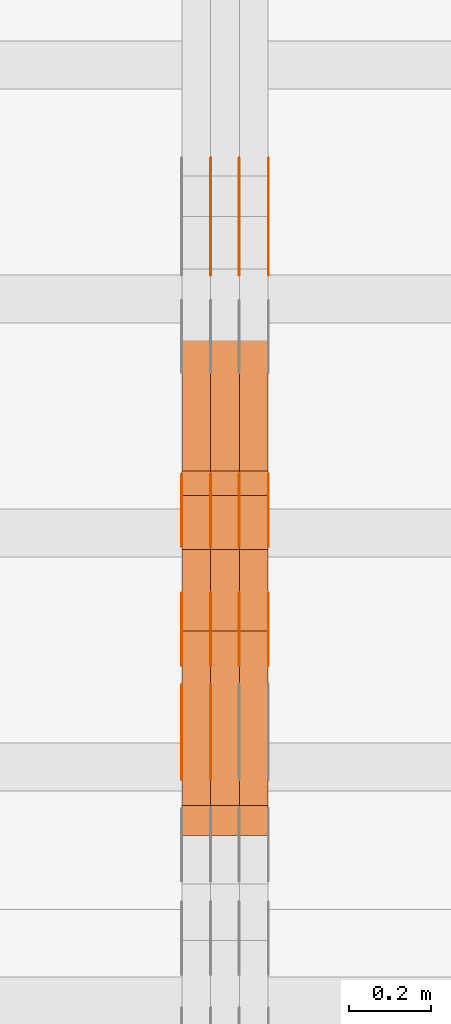
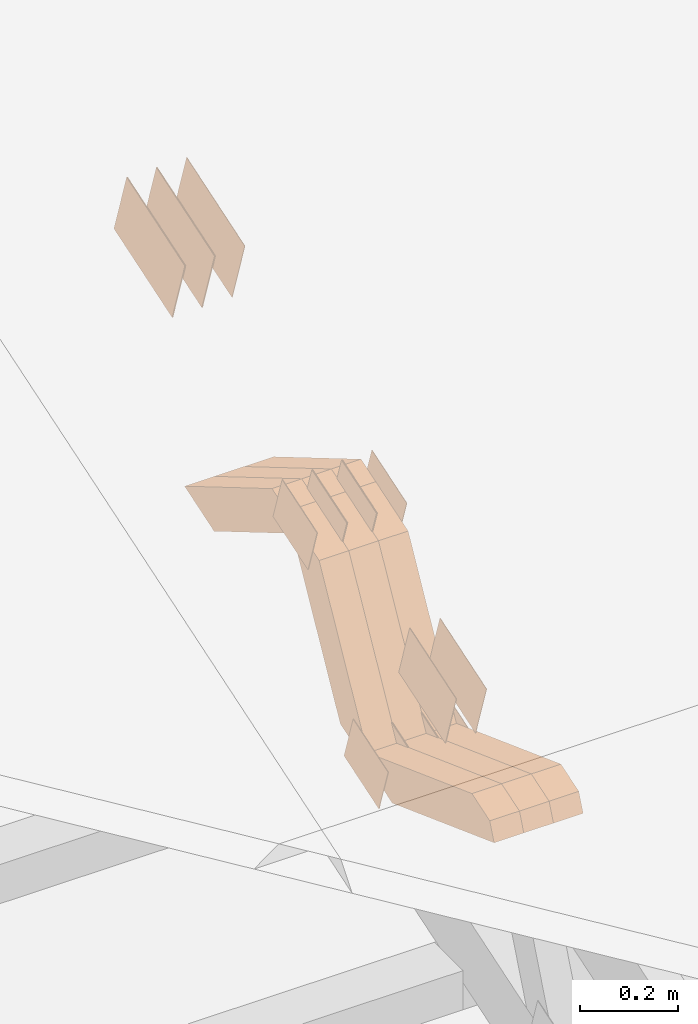
# One storey, part 120 of 385: 28 proxies.
"""IFC2X3 building model written with IfcOpenShell, lengths in millimetres."""

import ifcopenshell
import ifcopenshell.guid

model = None  # the IFC model being written
_history = None  # IfcOwnerHistory: only IFC2X3 demands one
_inside = {}  # id of a spatial element -> (the spatial element, [elements in it])
_under = {}  # id of a project, library or spatial element -> (it, [spatial elements below it])
_declared = {}  # id of a project -> (the project, [libraries it declares])
_typed = {}  # id of a type object -> (the type object, [elements of that type])
_made_of = {}  # id of a material, layer set ... -> (it, [elements and type objects made of it])


def new_model(schema):
    """Start an empty IFC model of exactly this schema.

    Asked for "IFC4X3", IfcOpenShell would pick the latest addendum, in which some entities
    have other attributes; the version numbers below select the first issue.
    IFC2X3 requires an IfcOwnerHistory on every rooted entity: one is made here for all.
    """
    global model, _history
    if schema == "IFC4X3":
        model = ifcopenshell.file(schema_version=(4, 3, 0, 0))
    else:
        model = ifcopenshell.file(schema=schema)
    _inside.clear()
    _under.clear()
    _declared.clear()
    _typed.clear()
    _made_of.clear()
    _history = None
    if model.schema == "IFC2X3":
        org = make("IfcOrganization", Name="unknown")
        user = make(
            "IfcPersonAndOrganization",
            ThePerson=make("IfcPerson", FamilyName="unknown"),
            TheOrganization=org,
        )
        app = make(
            "IfcApplication",
            ApplicationDeveloper=org,
            Version="unknown",
            ApplicationFullName="unknown",
            ApplicationIdentifier="unknown",
        )
        _history = make(
            "IfcOwnerHistory",
            OwningUser=user,
            OwningApplication=app,
            ChangeAction="ADDED",
            CreationDate=0,
        )
    return model


def make(cls, **values):
    """One entity of the class cls with the attributes given. An attribute that is None is left unset."""
    return model.create_entity(
        cls, **{name: value for name, value in values.items() if value is not None}
    )


def entity(cls, *values):
    """Any entity or typed value of the class cls, its attributes in the order of the schema. None: left unset."""
    e = model.create_entity(cls)
    for i, value in enumerate(values):
        if value is not None:
            e[i] = value
    return e


def rooted(cls, **values):
    """An entity with a GlobalId (a new one), such as an element, a storey or a relation."""
    return make(cls, GlobalId=ifcopenshell.guid.new(), OwnerHistory=_history, **values)


def si_unit(unit_type, name, prefix=None):
    """IfcSIUnit, for example si_unit("LENGTHUNIT", "METRE", prefix="MILLI")."""
    return make("IfcSIUnit", UnitType=unit_type, Prefix=prefix, Name=name)


def converted_unit(unit_type, name, factor, base, dimensions=None, offset=None):
    """IfcConversionBasedUnit, such as the inch: factor (a typed value) times the base unit."""
    return make(
        "IfcConversionBasedUnit"
        if offset is None
        else "IfcConversionBasedUnitWithOffset",
        ConversionOffset=offset,
        Dimensions=None
        if dimensions is None
        else entity("IfcDimensionalExponents", *dimensions),
        UnitType=unit_type,
        Name=name,
        ConversionFactor=make(
            "IfcMeasureWithUnit", ValueComponent=factor, UnitComponent=base
        ),
    )


def derived_unit(unit_type, elements):
    """IfcDerivedUnit: a product of units, each with its exponent."""
    return make(
        "IfcDerivedUnit",
        Elements=[
            make("IfcDerivedUnitElement", Unit=unit, Exponent=power)
            for unit, power in elements
        ],
        UnitType=unit_type,
    )


def assignment(units):
    """IfcUnitAssignment: the units of a project."""
    return None if units is None else make("IfcUnitAssignment", Units=units)


def point(xyz):
    """IfcCartesianPoint."""
    return None if xyz is None else make("IfcCartesianPoint", Coordinates=xyz)


def direction(xyz):
    """IfcDirection."""
    return None if xyz is None else make("IfcDirection", DirectionRatios=xyz)


def frame(location, z_axis=None, x_axis=None):
    """IfcAxis2Placement3D, a coordinate frame: its origin and axes. An axis left out is left unset."""
    return make(
        "IfcAxis2Placement3D",
        Location=point(location),
        Axis=direction(z_axis),
        RefDirection=direction(x_axis),
    )


def origin():
    """The frame at (0, 0, 0) with its axes left unset."""
    return frame((0.0, 0.0, 0.0))


def place(relative_to, where):
    """IfcLocalPlacement: puts the frame where relative to a parent placement (None: the world)."""
    return make(
        "IfcLocalPlacement", PlacementRelTo=relative_to, RelativePlacement=where
    )


def context(
    kind, dimensions, precision=None, world=None, true_north=None, identifier=None
):
    """IfcGeometricRepresentationContext, for example the 3D "Model" context."""
    return make(
        "IfcGeometricRepresentationContext",
        ContextIdentifier=identifier,
        ContextType=kind,
        CoordinateSpaceDimension=dimensions,
        Precision=precision,
        WorldCoordinateSystem=world,
        TrueNorth=true_north,
    )


def subcontext(parent, identifier, kind, view, scale=None):
    """IfcGeometricRepresentationSubContext, for example "Body" below "Model"."""
    return make(
        "IfcGeometricRepresentationSubContext",
        ContextIdentifier=identifier,
        ContextType=kind,
        ParentContext=parent,
        TargetScale=scale,
        TargetView=view,
    )


def project(units=None, contexts=None):
    """IfcProject with its units and contexts."""
    return rooted(
        "IfcProject",
        Name="project",
        RepresentationContexts=contexts,
        UnitsInContext=assignment(units),
    )


def spatial(cls, under=None, at=None, **own):
    """A site, building, storey or space (cls), placed at a placement, below another one or the project."""
    s = rooted(cls, ObjectPlacement=at, **own)
    if under is not None:
        _under.setdefault(under.id(), (under, []))[1].append(s)
    return s


def polyline(points):
    """IfcPolyline through the points."""
    return make("IfcPolyline", Points=[point(p) for p in points])


def outline(outer, holes=None, kind="AREA"):
    """IfcArbitraryClosedProfileDef: a profile drawn as a closed curve; with holes, ...WithVoids."""
    if holes is None:
        return make("IfcArbitraryClosedProfileDef", ProfileType=kind, OuterCurve=outer)
    return make(
        "IfcArbitraryProfileDefWithVoids",
        ProfileType=kind,
        OuterCurve=outer,
        InnerCurves=holes,
    )


def extrude(swept, where, along, depth):
    """IfcExtrudedAreaSolid: the profile swept, set in the frame where, extruded along a direction by depth."""
    return make(
        "IfcExtrudedAreaSolid",
        SweptArea=swept,
        Position=where,
        ExtrudedDirection=direction(along),
        Depth=depth,
    )


def shape(context_of_items, identifier, shape_type, items):
    """IfcShapeRepresentation: the items that make up one representation, for example the "Body"."""
    return make(
        "IfcShapeRepresentation",
        ContextOfItems=context_of_items,
        RepresentationIdentifier=identifier,
        RepresentationType=shape_type,
        Items=items,
    )


def source(mapping_origin, context_of_items, identifier, shape_type, items):
    """IfcRepresentationMap: a shape defined once, which mapped items show again and again."""
    return make(
        "IfcRepresentationMap",
        MappingOrigin=mapping_origin,
        MappedRepresentation=shape(context_of_items, identifier, shape_type, items),
    )


def transform(
    local_origin,
    x_axis=None,
    y_axis=None,
    z_axis=None,
    scale=None,
    scale2=None,
    scale3=None,
    uniform=True,
):
    """IfcCartesianTransformationOperator3D, or its non-uniform kind. x_axis, y_axis, z_axis: its Axis1, 2, 3."""
    if uniform:
        return make(
            "IfcCartesianTransformationOperator3D",
            Axis1=direction(x_axis),
            Axis2=direction(y_axis),
            LocalOrigin=point(local_origin),
            Scale=scale,
            Axis3=direction(z_axis),
        )
    return make(
        "IfcCartesianTransformationOperator3DnonUniform",
        Axis1=direction(x_axis),
        Axis2=direction(y_axis),
        LocalOrigin=point(local_origin),
        Scale=scale,
        Axis3=direction(z_axis),
        Scale2=scale2,
        Scale3=scale3,
    )


def mapped(mapping_source, mapping_target):
    """IfcMappedItem: shows the shape of a source again, moved by a transform."""
    return make(
        "IfcMappedItem", MappingSource=mapping_source, MappingTarget=mapping_target
    )


def material(Name=None, Category=None):
    """IfcMaterial."""
    return make("IfcMaterial", Name=Name, Category=Category)


def made_of(thing, what):
    """Note that an element or type object is made of a material, layer set ...; save() writes the relation."""
    if what is not None:
        _made_of.setdefault(what.id(), (what, []))[1].append(thing)
    return thing


def type_object(cls, material=None, **own):
    """A type object (cls), such as IfcWallType, which elements share."""
    return made_of(rooted(cls, **own), material)


def type_shapes(of_type, sources):
    """Give a type object the sources (RepresentationMaps) that its elements show as mapped items."""
    of_type.RepresentationMaps = sources


def element(
    cls,
    number,
    at=None,
    inside=None,
    cuts=None,
    type_object=None,
    material=None,
    context=None,
    identifier="Body",
    shape_type=None,
    held_by="IfcProductDefinitionShape",
    body=None,
    shapes=None,
    **own,
):
    """One element of the class cls, such as IfcWall. Its Tag is "e" and its number.

    at: its placement. inside: the storey or other place that contains it. cuts: it is an
    opening in that element (IfcRelVoidsElement). A single representation is given by context,
    identifier, shape_type and body (its items); several are given by shapes. held_by: the class
    of the entity that holds the representations. save() writes the other relations.
    """
    e = rooted(cls, Tag="e%d" % number, ObjectPlacement=at, **own)
    if body is not None:
        shapes = [shape(context, identifier, shape_type, body)]
    if shapes is not None:
        e.Representation = make(held_by, Representations=shapes)
    if inside is not None:
        _inside.setdefault(inside.id(), (inside, []))[1].append(e)
    if cuts is not None:
        rooted(
            "IfcRelVoidsElement", RelatingBuildingElement=cuts, RelatedOpeningElement=e
        )
    if type_object is not None:
        _typed.setdefault(type_object.id(), (type_object, []))[1].append(e)
    return made_of(e, material)


def aggregate(whole, parts):
    """IfcRelAggregates: a whole, such as a stair, and the parts it consists of."""
    return rooted("IfcRelAggregates", RelatingObject=whole, RelatedObjects=parts)


def save(model, path):
    """Write the relations noted so far, then the file.

    IfcRelAggregates (storeys below a building ...), IfcRelContainedInSpatialStructure (elements
    in a storey), IfcRelDefinesByType, IfcRelAssociatesMaterial and IfcRelDeclares: one each for
    every whole, place, type object, material and project.
    """
    for whole, parts in _under.values():
        aggregate(whole, parts)
    for where, things in _inside.values():
        rooted(
            "IfcRelContainedInSpatialStructure",
            RelatedElements=things,
            RelatingStructure=where,
        )
    for kind, things in _typed.values():
        rooted("IfcRelDefinesByType", RelatedObjects=things, RelatingType=kind)
    for what, things in _made_of.values():
        rooted("IfcRelAssociatesMaterial", RelatedObjects=things, RelatingMaterial=what)
    for by, libraries in _declared.values():
        rooted("IfcRelDeclares", RelatingContext=by, RelatedDefinitions=libraries)
    model.write(path)


model = new_model("IFC2X3")

# Units and contexts
model_context = context("Model", 3, precision=0.01, world=origin(), true_north=direction((6.12303176911189e-17, 1.0)))
body_context = subcontext(model_context, "Body", "Model", "MODEL_VIEW")
ifc_project = project(units=[si_unit("LENGTHUNIT", "METRE", prefix="MILLI"), si_unit("AREAUNIT", "SQUARE_METRE"), si_unit("VOLUMEUNIT", "CUBIC_METRE"), converted_unit("PLANEANGLEUNIT", "DEGREE", entity("IfcRatioMeasure", 0.0174532925199433), si_unit("PLANEANGLEUNIT", "RADIAN"), dimensions=[0, 0, 0, 0, 0, 0, 0]), si_unit("MASSUNIT", "GRAM", prefix="KILO"), derived_unit("MASSDENSITYUNIT", [(si_unit("MASSUNIT", "GRAM", prefix="KILO"), 1), (si_unit("LENGTHUNIT", "METRE"), -3)]), si_unit("TIMEUNIT", "SECOND"), si_unit("FREQUENCYUNIT", "HERTZ"), si_unit("THERMODYNAMICTEMPERATUREUNIT", "DEGREE_CELSIUS"), derived_unit("THERMALTRANSMITTANCEUNIT", [(si_unit("MASSUNIT", "GRAM", prefix="KILO"), 1), (si_unit("THERMODYNAMICTEMPERATUREUNIT", "KELVIN"), -1), (si_unit("TIMEUNIT", "SECOND"), -3)]), derived_unit("VOLUMETRICFLOWRATEUNIT", [(si_unit("LENGTHUNIT", "METRE"), 3), (si_unit("TIMEUNIT", "SECOND"), -1)]), si_unit("ELECTRICCURRENTUNIT", "AMPERE"), si_unit("ELECTRICVOLTAGEUNIT", "VOLT"), si_unit("POWERUNIT", "WATT"), si_unit("FORCEUNIT", "NEWTON", prefix="KILO"), si_unit("ILLUMINANCEUNIT", "LUX"), si_unit("LUMINOUSFLUXUNIT", "LUMEN"), si_unit("LUMINOUSINTENSITYUNIT", "CANDELA"), derived_unit("USERDEFINED", [(si_unit("MASSUNIT", "GRAM", prefix="KILO"), -1), (si_unit("LENGTHUNIT", "METRE"), -2), (si_unit("TIMEUNIT", "SECOND"), 3), (si_unit("LUMINOUSFLUXUNIT", "LUMEN"), 1)]), derived_unit("LINEARVELOCITYUNIT", [(si_unit("LENGTHUNIT", "METRE"), 1), (si_unit("TIMEUNIT", "SECOND"), -1)]), si_unit("PRESSUREUNIT", "PASCAL"), derived_unit("USERDEFINED", [(si_unit("LENGTHUNIT", "METRE"), -2), (si_unit("MASSUNIT", "GRAM", prefix="KILO"), 1), (si_unit("TIMEUNIT", "SECOND"), -2)])], contexts=[model_context])

# Site, building, storey
site_placement = place(None, origin())
site = spatial("IfcSite", under=ifc_project, at=site_placement, CompositionType="ELEMENT")
building_placement = place(site_placement, origin())
building = spatial("IfcBuilding", under=site, at=building_placement, CompositionType="ELEMENT")
storey_placement = place(building_placement, origin())
storey = spatial("IfcBuildingStorey", under=building, at=storey_placement, Name="Default", CompositionType="ELEMENT", Elevation=0.0)

# Proxies
ifc_material_1 = material(Name="IfcSurfaceStyle #280170")
building_element_proxy_type_1 = type_object("IfcBuildingElementProxyType", PredefinedType="NOTDEFINED", material=ifc_material_1)
shared_shape_1 = source(origin(), body_context, "Body", "SweptSolid", [
    extrude(outline(polyline([(-99.999644645517, -72.0000317581407), (100.000028485991, -72.0000317581407), (99.999644645517, 72.0000317581407), (-100.000028485991, 72.0000317581407), (-99.999644645517, -72.0000317581407)])), frame((100.000028485991, 72.0000317581407, 0.0), z_axis=(0.0, 0.0, 1.0), x_axis=(-1.0, 0.0, 0.0)), (0.0, 0.0, 1.0), 1.29999999999998),
])
type_shapes(building_element_proxy_type_1, [shared_shape_1])
proxy_1_placement = place(building_placement, frame((21246.3, 9012.6304394324, 2546.30522609783), z_axis=(-1.0, 0.0, 0.0), x_axis=(0.0, 0.951056516295154, 0.309016994374948)))
element("IfcBuildingElementProxy", 1, at=proxy_1_placement, inside=storey, type_object=building_element_proxy_type_1, material=ifc_material_1, context=body_context, shape_type="MappedRepresentation", body=[
    mapped(shared_shape_1, transform((0.0, 0.0, 0.0), scale=1.0)),
])
ifc_material_2 = material(Name="IfcSurfaceStyle #280113")
building_element_proxy_type_2 = type_object("IfcBuildingElementProxyType", PredefinedType="NOTDEFINED", material=ifc_material_2)
shared_shape_2 = source(origin(), body_context, "Body", "SweptSolid", [
    extrude(outline(polyline([(-99.999644645517, -72.0000317581407), (100.000028485991, -72.0000317581407), (99.999644645517, 72.0000317581407), (-100.000028485991, 72.0000317581407), (-99.999644645517, -72.0000317581407)])), frame((100.000028485991, 72.0000317581407, 0.0), z_axis=(0.0, 0.0, 1.0), x_axis=(-1.0, 0.0, 0.0)), (0.0, 0.0, 1.0), 1.29999999999999),
])
type_shapes(building_element_proxy_type_2, [shared_shape_2])
proxy_2_placement = place(building_placement, frame((21175.0, 9012.6304394324, 2546.30522609783), z_axis=(-1.0, 0.0, 0.0), x_axis=(0.0, 0.951056516295154, 0.309016994374948)))
element("IfcBuildingElementProxy", 2, at=proxy_2_placement, inside=storey, type_object=building_element_proxy_type_2, material=ifc_material_2, context=body_context, shape_type="MappedRepresentation", body=[
    mapped(shared_shape_2, transform((0.0, 0.0, 0.0), scale=1.0)),
])
ifc_material_3 = material(Name="IfcSurfaceStyle #280056")
building_element_proxy_type_3 = type_object("IfcBuildingElementProxyType", PredefinedType="NOTDEFINED", material=ifc_material_3)
shared_shape_3 = source(origin(), body_context, "Body", "SweptSolid", [
    extrude(outline(polyline([(-74.9998754286207, -60.0000016373506), (74.9998605591063, -60.0000016373506), (74.9998754286244, 60.0000016373506), (-74.9998605591099, 60.0000016373506), (-74.9998754286207, -60.0000016373506)])), frame((74.9998754286244, 60.0000016373506, 0.0), z_axis=(0.0, 0.0, 1.0), x_axis=(-1.0, 0.0, 0.0)), (0.0, 0.0, 1.0), 1.3),
])
type_shapes(building_element_proxy_type_3, [shared_shape_3])
proxy_3_placement = place(building_placement, frame((21386.3, 9580.89841427132, 2615.81135078741), z_axis=(-1.0, 0.0, 0.0), x_axis=(0.0, 0.951056516295154, 0.309016994374948)))
element("IfcBuildingElementProxy", 3, at=proxy_3_placement, inside=storey, type_object=building_element_proxy_type_3, material=ifc_material_3, context=body_context, shape_type="MappedRepresentation", body=[
    mapped(shared_shape_3, transform((0.0, 0.0, 0.0), scale=1.0)),
])
ifc_material_4 = material(Name="IfcSurfaceStyle #279999")
building_element_proxy_type_4 = type_object("IfcBuildingElementProxyType", PredefinedType="NOTDEFINED", material=ifc_material_4)
shared_shape_4 = source(origin(), body_context, "Body", "SweptSolid", [
    extrude(outline(polyline([(-74.9998754286207, -60.0000016373506), (74.9998605591063, -60.0000016373506), (74.9998754286244, 60.0000016373506), (-74.9998605591099, 60.0000016373506), (-74.9998754286207, -60.0000016373506)])), frame((74.9998754286244, 60.0000016373506, 0.0), z_axis=(0.0, 0.0, 1.0), x_axis=(-1.0, 0.0, 0.0)), (0.0, 0.0, 1.0), 1.3),
])
type_shapes(building_element_proxy_type_4, [shared_shape_4])
proxy_4_placement = place(building_placement, frame((21315.0, 9580.89841427132, 2615.81135078741), z_axis=(-1.0, 0.0, 0.0), x_axis=(0.0, 0.951056516295154, 0.309016994374948)))
element("IfcBuildingElementProxy", 4, at=proxy_4_placement, inside=storey, type_object=building_element_proxy_type_4, material=ifc_material_4, context=body_context, shape_type="MappedRepresentation", body=[
    mapped(shared_shape_4, transform((0.0, 0.0, 0.0), scale=1.0)),
])
ifc_material_5 = material(Name="IfcSurfaceStyle #279942")
building_element_proxy_type_5 = type_object("IfcBuildingElementProxyType", PredefinedType="NOTDEFINED", material=ifc_material_5)
shared_shape_5 = source(origin(), body_context, "Body", "SweptSolid", [
    extrude(outline(polyline([(-74.9998754286207, -60.0000016373506), (74.9998605591063, -60.0000016373506), (74.9998754286244, 60.0000016373506), (-74.9998605591099, 60.0000016373506), (-74.9998754286207, -60.0000016373506)])), frame((74.9998754286244, 60.0000016373506, 0.0), z_axis=(0.0, 0.0, 1.0), x_axis=(-1.0, 0.0, 0.0)), (0.0, 0.0, 1.0), 1.3),
])
type_shapes(building_element_proxy_type_5, [shared_shape_5])
proxy_5_placement = place(building_placement, frame((21316.3, 9580.89841427132, 2615.81135078741), z_axis=(-1.0, 0.0, 0.0), x_axis=(0.0, 0.951056516295154, 0.309016994374948)))
element("IfcBuildingElementProxy", 5, at=proxy_5_placement, inside=storey, type_object=building_element_proxy_type_5, material=ifc_material_5, context=body_context, shape_type="MappedRepresentation", body=[
    mapped(shared_shape_5, transform((0.0, 0.0, 0.0), scale=1.0)),
])
ifc_material_6 = material(Name="IfcSurfaceStyle #279885")
building_element_proxy_type_6 = type_object("IfcBuildingElementProxyType", PredefinedType="NOTDEFINED", material=ifc_material_6)
shared_shape_6 = source(origin(), body_context, "Body", "SweptSolid", [
    extrude(outline(polyline([(-74.9998754286207, -60.0000016373506), (74.9998605591063, -60.0000016373506), (74.9998754286244, 60.0000016373506), (-74.9998605591099, 60.0000016373506), (-74.9998754286207, -60.0000016373506)])), frame((74.9998754286244, 60.0000016373506, 0.0), z_axis=(0.0, 0.0, 1.0), x_axis=(-1.0, 0.0, 0.0)), (0.0, 0.0, 1.0), 1.29999999999999),
])
type_shapes(building_element_proxy_type_6, [shared_shape_6])
proxy_6_placement = place(building_placement, frame((21245.0, 9580.89841427132, 2615.81135078741), z_axis=(-1.0, 0.0, 0.0), x_axis=(0.0, 0.951056516295154, 0.309016994374948)))
element("IfcBuildingElementProxy", 6, at=proxy_6_placement, inside=storey, type_object=building_element_proxy_type_6, material=ifc_material_6, context=body_context, shape_type="MappedRepresentation", body=[
    mapped(shared_shape_6, transform((0.0, 0.0, 0.0), scale=1.0)),
])
ifc_material_7 = material(Name="IfcSurfaceStyle #279828")
building_element_proxy_type_7 = type_object("IfcBuildingElementProxyType", PredefinedType="NOTDEFINED", material=ifc_material_7)
shared_shape_7 = source(origin(), body_context, "Body", "SweptSolid", [
    extrude(outline(polyline([(-74.9998754286207, -60.0000016373506), (74.9998605591063, -60.0000016373506), (74.9998754286244, 60.0000016373506), (-74.9998605591099, 60.0000016373506), (-74.9998754286207, -60.0000016373506)])), frame((74.9998754286244, 60.0000016373506, 0.0), z_axis=(0.0, 0.0, 1.0), x_axis=(-1.0, 0.0, 0.0)), (0.0, 0.0, 1.0), 1.29999999999999),
])
type_shapes(building_element_proxy_type_7, [shared_shape_7])
proxy_7_placement = place(building_placement, frame((21246.3, 9580.89841427132, 2615.81135078741), z_axis=(-1.0, 0.0, 0.0), x_axis=(0.0, 0.951056516295154, 0.309016994374948)))
element("IfcBuildingElementProxy", 7, at=proxy_7_placement, inside=storey, type_object=building_element_proxy_type_7, material=ifc_material_7, context=body_context, shape_type="MappedRepresentation", body=[
    mapped(shared_shape_7, transform((0.0, 0.0, 0.0), scale=1.0)),
])
ifc_material_8 = material(Name="IfcSurfaceStyle #279771")
building_element_proxy_type_8 = type_object("IfcBuildingElementProxyType", PredefinedType="NOTDEFINED", material=ifc_material_8)
shared_shape_8 = source(origin(), body_context, "Body", "SweptSolid", [
    extrude(outline(polyline([(-74.9998754286207, -60.0000016373506), (74.9998605591063, -60.0000016373506), (74.9998754286244, 60.0000016373506), (-74.9998605591099, 60.0000016373506), (-74.9998754286207, -60.0000016373506)])), frame((74.9998754286244, 60.0000016373506, 0.0), z_axis=(0.0, 0.0, 1.0), x_axis=(-1.0, 0.0, 0.0)), (0.0, 0.0, 1.0), 1.29999999999999),
])
type_shapes(building_element_proxy_type_8, [shared_shape_8])
proxy_8_placement = place(building_placement, frame((21175.0, 9580.89841427132, 2615.81135078741), z_axis=(-1.0, 0.0, 0.0), x_axis=(0.0, 0.951056516295154, 0.309016994374948)))
element("IfcBuildingElementProxy", 8, at=proxy_8_placement, inside=storey, type_object=building_element_proxy_type_8, material=ifc_material_8, context=body_context, shape_type="MappedRepresentation", body=[
    mapped(shared_shape_8, transform((0.0, 0.0, 0.0), scale=1.0)),
])
ifc_material_9 = material(Name="IfcSurfaceStyle #279030")
building_element_proxy_type_9 = type_object("IfcBuildingElementProxyType", PredefinedType="NOTDEFINED", material=ifc_material_9)
shared_shape_9 = source(origin(), body_context, "Body", "SweptSolid", [
    extrude(outline(polyline([(-75.0008041947458, -59.9996998629349), (75.0007893252423, -59.9996998629349), (75.0008041947458, 59.9996998629349), (-75.0007893252423, 59.9996998629349), (-75.0008041947458, -59.9996998629349)])), frame((75.0008041947458, 60.0002282421692, 0.0), z_axis=(0.0, 0.0, 1.0), x_axis=(-1.0, 0.0, 0.0)), (0.0, 0.0, 1.0), 1.3),
])
type_shapes(building_element_proxy_type_9, [shared_shape_9])
proxy_9_placement = place(building_placement, frame((21386.3, 9291.048828125, 2194.94482421875), z_axis=(-1.0, 0.0, 0.0), x_axis=(0.0, 0.951056516295124, 0.309016994375039)))
element("IfcBuildingElementProxy", 9, at=proxy_9_placement, inside=storey, type_object=building_element_proxy_type_9, material=ifc_material_9, context=body_context, shape_type="MappedRepresentation", body=[
    mapped(shared_shape_9, transform((0.0, 0.0, 0.0), scale=1.0)),
])
ifc_material_10 = material(Name="IfcSurfaceStyle #278973")
building_element_proxy_type_10 = type_object("IfcBuildingElementProxyType", PredefinedType="NOTDEFINED", material=ifc_material_10)
shared_shape_10 = source(origin(), body_context, "Body", "SweptSolid", [
    extrude(outline(polyline([(-75.0008041947458, -59.9996998629349), (75.0007893252423, -59.9996998629349), (75.0008041947458, 59.9996998629349), (-75.0007893252423, 59.9996998629349), (-75.0008041947458, -59.9996998629349)])), frame((75.0008041947458, 60.0002282421692, 0.0), z_axis=(0.0, 0.0, 1.0), x_axis=(-1.0, 0.0, 0.0)), (0.0, 0.0, 1.0), 1.3),
])
type_shapes(building_element_proxy_type_10, [shared_shape_10])
proxy_10_placement = place(building_placement, frame((21315.0, 9291.048828125, 2194.94482421875), z_axis=(-1.0, 0.0, 0.0), x_axis=(0.0, 0.951056516295124, 0.309016994375039)))
element("IfcBuildingElementProxy", 10, at=proxy_10_placement, inside=storey, type_object=building_element_proxy_type_10, material=ifc_material_10, context=body_context, shape_type="MappedRepresentation", body=[
    mapped(shared_shape_10, transform((0.0, 0.0, 0.0), scale=1.0)),
])
ifc_material_11 = material(Name="IfcSurfaceStyle #278916")
building_element_proxy_type_11 = type_object("IfcBuildingElementProxyType", PredefinedType="NOTDEFINED", material=ifc_material_11)
shared_shape_11 = source(origin(), body_context, "Body", "SweptSolid", [
    extrude(outline(polyline([(-75.0008041947458, -59.9996998629349), (75.0007893252423, -59.9996998629349), (75.0008041947458, 59.9996998629349), (-75.0007893252423, 59.9996998629349), (-75.0008041947458, -59.9996998629349)])), frame((75.0008041947458, 60.0002282421692, 0.0), z_axis=(0.0, 0.0, 1.0), x_axis=(-1.0, 0.0, 0.0)), (0.0, 0.0, 1.0), 1.3),
])
type_shapes(building_element_proxy_type_11, [shared_shape_11])
proxy_11_placement = place(building_placement, frame((21316.3, 9291.048828125, 2194.94482421875), z_axis=(-1.0, 0.0, 0.0), x_axis=(0.0, 0.951056516295124, 0.309016994375039)))
element("IfcBuildingElementProxy", 11, at=proxy_11_placement, inside=storey, type_object=building_element_proxy_type_11, material=ifc_material_11, context=body_context, shape_type="MappedRepresentation", body=[
    mapped(shared_shape_11, transform((0.0, 0.0, 0.0), scale=1.0)),
])
ifc_material_12 = material(Name="IfcSurfaceStyle #278859")
building_element_proxy_type_12 = type_object("IfcBuildingElementProxyType", PredefinedType="NOTDEFINED", material=ifc_material_12)
shared_shape_12 = source(origin(), body_context, "Body", "SweptSolid", [
    extrude(outline(polyline([(-75.0008041947458, -59.9996998629349), (75.0007893252423, -59.9996998629349), (75.0008041947458, 59.9996998629349), (-75.0007893252423, 59.9996998629349), (-75.0008041947458, -59.9996998629349)])), frame((75.0008041947458, 60.0002282421692, 0.0), z_axis=(0.0, 0.0, 1.0), x_axis=(-1.0, 0.0, 0.0)), (0.0, 0.0, 1.0), 1.29999999999999),
])
type_shapes(building_element_proxy_type_12, [shared_shape_12])
proxy_12_placement = place(building_placement, frame((21245.0, 9291.048828125, 2194.94482421875), z_axis=(-1.0, 0.0, 0.0), x_axis=(0.0, 0.951056516295124, 0.309016994375039)))
element("IfcBuildingElementProxy", 12, at=proxy_12_placement, inside=storey, type_object=building_element_proxy_type_12, material=ifc_material_12, context=body_context, shape_type="MappedRepresentation", body=[
    mapped(shared_shape_12, transform((0.0, 0.0, 0.0), scale=1.0)),
])
ifc_material_13 = material(Name="IfcSurfaceStyle #278802")
building_element_proxy_type_13 = type_object("IfcBuildingElementProxyType", PredefinedType="NOTDEFINED", material=ifc_material_13)
shared_shape_13 = source(origin(), body_context, "Body", "SweptSolid", [
    extrude(outline(polyline([(-75.0008041947458, -59.9996998629349), (75.0007893252423, -59.9996998629349), (75.0008041947458, 59.9996998629349), (-75.0007893252423, 59.9996998629349), (-75.0008041947458, -59.9996998629349)])), frame((75.0008041947458, 60.0002282421692, 0.0), z_axis=(0.0, 0.0, 1.0), x_axis=(-1.0, 0.0, 0.0)), (0.0, 0.0, 1.0), 1.29999999999999),
])
type_shapes(building_element_proxy_type_13, [shared_shape_13])
proxy_13_placement = place(building_placement, frame((21246.3, 9291.048828125, 2194.94482421875), z_axis=(-1.0, 0.0, 0.0), x_axis=(0.0, 0.951056516295124, 0.309016994375039)))
element("IfcBuildingElementProxy", 13, at=proxy_13_placement, inside=storey, type_object=building_element_proxy_type_13, material=ifc_material_13, context=body_context, shape_type="MappedRepresentation", body=[
    mapped(shared_shape_13, transform((0.0, 0.0, 0.0), scale=1.0)),
])
ifc_material_14 = material(Name="IfcSurfaceStyle #278745")
building_element_proxy_type_14 = type_object("IfcBuildingElementProxyType", PredefinedType="NOTDEFINED", material=ifc_material_14)
shared_shape_14 = source(origin(), body_context, "Body", "SweptSolid", [
    extrude(outline(polyline([(-75.0008041947458, -59.9996998629349), (75.0007893252423, -59.9996998629349), (75.0008041947458, 59.9996998629349), (-75.0007893252423, 59.9996998629349), (-75.0008041947458, -59.9996998629349)])), frame((75.0008041947458, 60.0002282421692, 0.0), z_axis=(0.0, 0.0, 1.0), x_axis=(-1.0, 0.0, 0.0)), (0.0, 0.0, 1.0), 1.29999999999999),
])
type_shapes(building_element_proxy_type_14, [shared_shape_14])
proxy_14_placement = place(building_placement, frame((21175.0, 9291.048828125, 2194.94482421875), z_axis=(-1.0, 0.0, 0.0), x_axis=(0.0, 0.951056516295124, 0.309016994375039)))
element("IfcBuildingElementProxy", 14, at=proxy_14_placement, inside=storey, type_object=building_element_proxy_type_14, material=ifc_material_14, context=body_context, shape_type="MappedRepresentation", body=[
    mapped(shared_shape_14, transform((0.0, 0.0, 0.0), scale=1.0)),
])
ifc_material_15 = material(Name="IfcSurfaceStyle #278688")
building_element_proxy_type_15 = type_object("IfcBuildingElementProxyType", PredefinedType="NOTDEFINED", material=ifc_material_15)
shared_shape_15 = source(origin(), body_context, "Body", "SweptSolid", [
    extrude(outline(polyline([(-124.999432723313, -83.9999457831645), (125.000177551971, -83.9999457831645), (124.999395001513, 83.9999457831646), (-125.000139830171, 83.9999457831645), (-124.999432723313, -83.9999457831645)])), frame((125.000177551971, 84.0001194377192, 0.0), z_axis=(0.0, 0.0, 1.0), x_axis=(-1.0, 0.0, 0.0)), (0.0, 0.0, 1.0), 1.3),
])
type_shapes(building_element_proxy_type_15, [shared_shape_15])
proxy_15_placement = place(building_placement, frame((21386.3, 10242.0968435406, 2855.88278137571), z_axis=(-1.0, 0.0, 0.0), x_axis=(0.0, 0.951056516295154, 0.309016994374948)))
element("IfcBuildingElementProxy", 15, at=proxy_15_placement, inside=storey, type_object=building_element_proxy_type_15, material=ifc_material_15, context=body_context, shape_type="MappedRepresentation", body=[
    mapped(shared_shape_15, transform((0.0, 0.0, 0.0), scale=1.0)),
])
ifc_material_16 = material(Name="IfcSurfaceStyle #278631")
building_element_proxy_type_16 = type_object("IfcBuildingElementProxyType", PredefinedType="NOTDEFINED", material=ifc_material_16)
shared_shape_16 = source(origin(), body_context, "Body", "SweptSolid", [
    extrude(outline(polyline([(-124.999432723313, -83.9999457831645), (125.000177551971, -83.9999457831645), (124.999395001513, 83.9999457831646), (-125.000139830171, 83.9999457831645), (-124.999432723313, -83.9999457831645)])), frame((125.000177551971, 84.0001194377192, 0.0), z_axis=(0.0, 0.0, 1.0), x_axis=(-1.0, 0.0, 0.0)), (0.0, 0.0, 1.0), 1.3),
])
type_shapes(building_element_proxy_type_16, [shared_shape_16])
proxy_16_placement = place(building_placement, frame((21315.0, 10242.0968435406, 2855.88278137571), z_axis=(-1.0, 0.0, 0.0), x_axis=(0.0, 0.951056516295154, 0.309016994374948)))
element("IfcBuildingElementProxy", 16, at=proxy_16_placement, inside=storey, type_object=building_element_proxy_type_16, material=ifc_material_16, context=body_context, shape_type="MappedRepresentation", body=[
    mapped(shared_shape_16, transform((0.0, 0.0, 0.0), scale=1.0)),
])
ifc_material_17 = material(Name="IfcSurfaceStyle #278574")
building_element_proxy_type_17 = type_object("IfcBuildingElementProxyType", PredefinedType="NOTDEFINED", material=ifc_material_17)
shared_shape_17 = source(origin(), body_context, "Body", "SweptSolid", [
    extrude(outline(polyline([(-124.999432723313, -83.9999457831645), (125.000177551971, -83.9999457831645), (124.999395001513, 83.9999457831646), (-125.000139830171, 83.9999457831645), (-124.999432723313, -83.9999457831645)])), frame((125.000177551971, 84.0001194377192, 0.0), z_axis=(0.0, 0.0, 1.0), x_axis=(-1.0, 0.0, 0.0)), (0.0, 0.0, 1.0), 1.3),
])
type_shapes(building_element_proxy_type_17, [shared_shape_17])
proxy_17_placement = place(building_placement, frame((21316.3, 10242.0968435406, 2855.88278137571), z_axis=(-1.0, 0.0, 0.0), x_axis=(0.0, 0.951056516295154, 0.309016994374948)))
element("IfcBuildingElementProxy", 17, at=proxy_17_placement, inside=storey, type_object=building_element_proxy_type_17, material=ifc_material_17, context=body_context, shape_type="MappedRepresentation", body=[
    mapped(shared_shape_17, transform((0.0, 0.0, 0.0), scale=1.0)),
])
ifc_material_18 = material(Name="IfcSurfaceStyle #278517")
building_element_proxy_type_18 = type_object("IfcBuildingElementProxyType", PredefinedType="NOTDEFINED", material=ifc_material_18)
shared_shape_18 = source(origin(), body_context, "Body", "SweptSolid", [
    extrude(outline(polyline([(-124.999432723313, -83.9999457831645), (125.000177551971, -83.9999457831645), (124.999395001513, 83.9999457831646), (-125.000139830171, 83.9999457831645), (-124.999432723313, -83.9999457831645)])), frame((125.000177551971, 84.0001194377192, 0.0), z_axis=(0.0, 0.0, 1.0), x_axis=(-1.0, 0.0, 0.0)), (0.0, 0.0, 1.0), 1.29999999999998),
])
type_shapes(building_element_proxy_type_18, [shared_shape_18])
proxy_18_placement = place(building_placement, frame((21245.0, 10242.0968435406, 2855.88278137571), z_axis=(-1.0, 0.0, 0.0), x_axis=(0.0, 0.951056516295154, 0.309016994374948)))
element("IfcBuildingElementProxy", 18, at=proxy_18_placement, inside=storey, type_object=building_element_proxy_type_18, material=ifc_material_18, context=body_context, shape_type="MappedRepresentation", body=[
    mapped(shared_shape_18, transform((0.0, 0.0, 0.0), scale=1.0)),
])
ifc_material_19 = material(Name="IfcSurfaceStyle #278460")
building_element_proxy_type_19 = type_object("IfcBuildingElementProxyType", PredefinedType="NOTDEFINED", material=ifc_material_19)
shared_shape_19 = source(origin(), body_context, "Body", "SweptSolid", [
    extrude(outline(polyline([(-124.999432723313, -83.9999457831645), (125.000177551971, -83.9999457831645), (124.999395001513, 83.9999457831646), (-125.000139830171, 83.9999457831645), (-124.999432723313, -83.9999457831645)])), frame((125.000177551971, 84.0001194377192, 0.0), z_axis=(0.0, 0.0, 1.0), x_axis=(-1.0, 0.0, 0.0)), (0.0, 0.0, 1.0), 1.29999999999998),
])
type_shapes(building_element_proxy_type_19, [shared_shape_19])
proxy_19_placement = place(building_placement, frame((21246.3, 10242.0968435406, 2855.88278137571), z_axis=(-1.0, 0.0, 0.0), x_axis=(0.0, 0.951056516295154, 0.309016994374948)))
element("IfcBuildingElementProxy", 19, at=proxy_19_placement, inside=storey, type_object=building_element_proxy_type_19, material=ifc_material_19, context=body_context, shape_type="MappedRepresentation", body=[
    mapped(shared_shape_19, transform((0.0, 0.0, 0.0), scale=1.0)),
])
ifc_material_20 = material(Name="IfcSurfaceStyle #255864")
building_element_proxy_type_20 = type_object("IfcBuildingElementProxyType", Name="T1-W43 255862", PredefinedType="NOTDEFINED", material=ifc_material_20)
shared_shape_20 = source(origin(), body_context, "Body", "SweptSolid", [
    extrude(outline(polyline([(-198.159905426436, -47.4999961988362), (173.155878681738, -47.4999961988362), (174.585865234707, -0.00038778214839239), (132.582704932703, 47.5001900899104), (-282.164543422712, 47.5001900899104), (-198.159905426436, -47.4999961988362)])), frame((174.585865234707, 47.5001900899104, 0.0), z_axis=(0.0, 0.0, 1.0), x_axis=(-1.0, 0.0, 0.0)), (0.0, 0.0, 1.0), 70.0),
])
type_shapes(building_element_proxy_type_20, [shared_shape_20])
proxy_20_placement = place(building_placement, frame((21385.0, 9730.71877771152, 2634.4881681647), z_axis=(-1.0, 0.0, 0.0), x_axis=(0.0, 0.861495156633645, -0.507765787639115)))
element("IfcBuildingElementProxy", 20, at=proxy_20_placement, inside=storey, type_object=building_element_proxy_type_20, material=ifc_material_20, Name="T1-W43", context=body_context, shape_type="MappedRepresentation", body=[
    mapped(shared_shape_20, transform((0.0, 0.0, 0.0), scale=1.0)),
])
ifc_material_21 = material(Name="IfcSurfaceStyle #255798")
building_element_proxy_type_21 = type_object("IfcBuildingElementProxyType", Name="T1-W43 255796", PredefinedType="NOTDEFINED", material=ifc_material_21)
shared_shape_21 = source(origin(), body_context, "Body", "SweptSolid", [
    extrude(outline(polyline([(-198.159905426436, -47.4999961988362), (173.155878681738, -47.4999961988362), (174.585865234707, -0.00038778214839239), (132.582704932703, 47.5001900899104), (-282.164543422712, 47.5001900899104), (-198.159905426436, -47.4999961988362)])), frame((174.585865234707, 47.5001900899104, 0.0), z_axis=(0.0, 0.0, 1.0), x_axis=(-1.0, 0.0, 0.0)), (0.0, 0.0, 1.0), 70.0),
])
type_shapes(building_element_proxy_type_21, [shared_shape_21])
proxy_21_placement = place(building_placement, frame((21315.0, 9730.71877771152, 2634.4881681647), z_axis=(-1.0, 0.0, 0.0), x_axis=(0.0, 0.861495156633645, -0.507765787639115)))
element("IfcBuildingElementProxy", 21, at=proxy_21_placement, inside=storey, type_object=building_element_proxy_type_21, material=ifc_material_21, Name="T1-W43", context=body_context, shape_type="MappedRepresentation", body=[
    mapped(shared_shape_21, transform((0.0, 0.0, 0.0), scale=1.0)),
])
ifc_material_22 = material(Name="IfcSurfaceStyle #255732")
building_element_proxy_type_22 = type_object("IfcBuildingElementProxyType", Name="T1-W43 255730", PredefinedType="NOTDEFINED", material=ifc_material_22)
shared_shape_22 = source(origin(), body_context, "Body", "SweptSolid", [
    extrude(outline(polyline([(-198.159905426436, -47.4999961988362), (173.155878681738, -47.4999961988362), (174.585865234707, -0.00038778214839239), (132.582704932703, 47.5001900899104), (-282.164543422712, 47.5001900899104), (-198.159905426436, -47.4999961988362)])), frame((174.585865234707, 47.5001900899104, 0.0), z_axis=(0.0, 0.0, 1.0), x_axis=(-1.0, 0.0, 0.0)), (0.0, 0.0, 1.0), 70.0),
])
type_shapes(building_element_proxy_type_22, [shared_shape_22])
proxy_22_placement = place(building_placement, frame((21245.0, 9730.71877771152, 2634.4881681647), z_axis=(-1.0, 0.0, 0.0), x_axis=(0.0, 0.861495156633645, -0.507765787639115)))
element("IfcBuildingElementProxy", 22, at=proxy_22_placement, inside=storey, type_object=building_element_proxy_type_22, material=ifc_material_22, Name="T1-W43", context=body_context, shape_type="MappedRepresentation", body=[
    mapped(shared_shape_22, transform((0.0, 0.0, 0.0), scale=1.0)),
])
ifc_material_23 = material(Name="IfcSurfaceStyle #255468")
building_element_proxy_type_23 = type_object("IfcBuildingElementProxyType", Name="T1-W33 255466", PredefinedType="NOTDEFINED", material=ifc_material_23)
shared_shape_23 = source(origin(), body_context, "Body", "SweptSolid", [
    extrude(outline(polyline([(-314.173070820175, -47.4997758466969), (139.635944117881, -47.4997758466969), (190.204920608233, 0.000348187720347082), (197.369205310989, 47.5001702328475), (-213.036999216928, 47.4990332728259), (-314.173070820175, -47.4997758466969)])), frame((197.369205310989, 47.5001702328475, 0.0), z_axis=(0.0, 0.0, 1.0), x_axis=(-1.0, 0.0, 0.0)), (0.0, 0.0, 1.0), 70.0),
])
type_shapes(building_element_proxy_type_23, [shared_shape_23])
proxy_23_placement = place(building_placement, frame((21385.0, 9376.96875, 2191.01977539063), z_axis=(-1.0, 0.0, 0.0), x_axis=(0.0, 0.481632628948835, 0.876373214293907)))
element("IfcBuildingElementProxy", 23, at=proxy_23_placement, inside=storey, type_object=building_element_proxy_type_23, material=ifc_material_23, Name="T1-W33", context=body_context, shape_type="MappedRepresentation", body=[
    mapped(shared_shape_23, transform((0.0, 0.0, 0.0), scale=1.0)),
])
ifc_material_24 = material(Name="IfcSurfaceStyle #255402")
building_element_proxy_type_24 = type_object("IfcBuildingElementProxyType", Name="T1-W33 255400", PredefinedType="NOTDEFINED", material=ifc_material_24)
shared_shape_24 = source(origin(), body_context, "Body", "SweptSolid", [
    extrude(outline(polyline([(-314.173070820175, -47.4997758466969), (139.635944117881, -47.4997758466969), (190.204920608233, 0.000348187720347082), (197.369205310989, 47.5001702328475), (-213.036999216928, 47.4990332728259), (-314.173070820175, -47.4997758466969)])), frame((197.369205310989, 47.5001702328475, 0.0), z_axis=(0.0, 0.0, 1.0), x_axis=(-1.0, 0.0, 0.0)), (0.0, 0.0, 1.0), 70.0),
])
type_shapes(building_element_proxy_type_24, [shared_shape_24])
proxy_24_placement = place(building_placement, frame((21315.0, 9376.96875, 2191.01977539063), z_axis=(-1.0, 0.0, 0.0), x_axis=(0.0, 0.481632628948835, 0.876373214293907)))
element("IfcBuildingElementProxy", 24, at=proxy_24_placement, inside=storey, type_object=building_element_proxy_type_24, material=ifc_material_24, Name="T1-W33", context=body_context, shape_type="MappedRepresentation", body=[
    mapped(shared_shape_24, transform((0.0, 0.0, 0.0), scale=1.0)),
])
ifc_material_25 = material(Name="IfcSurfaceStyle #255336")
building_element_proxy_type_25 = type_object("IfcBuildingElementProxyType", Name="T1-W33 255334", PredefinedType="NOTDEFINED", material=ifc_material_25)
shared_shape_25 = source(origin(), body_context, "Body", "SweptSolid", [
    extrude(outline(polyline([(-314.173070820175, -47.4997758466969), (139.635944117881, -47.4997758466969), (190.204920608233, 0.000348187720347082), (197.369205310989, 47.5001702328475), (-213.036999216928, 47.4990332728259), (-314.173070820175, -47.4997758466969)])), frame((197.369205310989, 47.5001702328475, 0.0), z_axis=(0.0, 0.0, 1.0), x_axis=(-1.0, 0.0, 0.0)), (0.0, 0.0, 1.0), 70.0),
])
type_shapes(building_element_proxy_type_25, [shared_shape_25])
proxy_25_placement = place(building_placement, frame((21245.0, 9376.96875, 2191.01977539063), z_axis=(-1.0, 0.0, 0.0), x_axis=(0.0, 0.481632628948835, 0.876373214293907)))
element("IfcBuildingElementProxy", 25, at=proxy_25_placement, inside=storey, type_object=building_element_proxy_type_25, material=ifc_material_25, Name="T1-W33", context=body_context, shape_type="MappedRepresentation", body=[
    mapped(shared_shape_25, transform((0.0, 0.0, 0.0), scale=1.0)),
])
ifc_material_26 = material(Name="IfcSurfaceStyle #255072")
building_element_proxy_type_26 = type_object("IfcBuildingElementProxyType", Name="T1-W25 255070", PredefinedType="NOTDEFINED", material=ifc_material_26)
shared_shape_26 = source(origin(), body_context, "Body", "SweptSolid", [
    extrude(outline(polyline([(-229.232772462784, -47.5001671709529), (214.075939394384, -47.5001671709529), (212.688957821661, -0.000141058964427199), (152.358910178478, 47.5002377004352), (-349.891034931738, 47.5002377004352), (-229.232772462784, -47.5001671709529)])), frame((214.075939394384, 47.5002377004352, 0.0), z_axis=(0.0, 0.0, 1.0), x_axis=(-1.0, 0.0, 0.0)), (0.0, 0.0, 1.0), 70.0),
])
type_shapes(building_element_proxy_type_26, [shared_shape_26])
proxy_26_placement = place(building_placement, frame((21385.0, 8892.81895960242, 2369.29665807578), z_axis=(-1.0, 0.0, 0.0), x_axis=(0.0, 0.938402514401222, -0.345544094097213)))
element("IfcBuildingElementProxy", 26, at=proxy_26_placement, inside=storey, type_object=building_element_proxy_type_26, material=ifc_material_26, Name="T1-W25", context=body_context, shape_type="MappedRepresentation", body=[
    mapped(shared_shape_26, transform((0.0, 0.0, 0.0), scale=1.0)),
])
ifc_material_27 = material(Name="IfcSurfaceStyle #255006")
building_element_proxy_type_27 = type_object("IfcBuildingElementProxyType", Name="T1-W25 255004", PredefinedType="NOTDEFINED", material=ifc_material_27)
shared_shape_27 = source(origin(), body_context, "Body", "SweptSolid", [
    extrude(outline(polyline([(-229.232772462784, -47.5001671709529), (214.075939394384, -47.5001671709529), (212.688957821661, -0.000141058964427199), (152.358910178478, 47.5002377004352), (-349.891034931738, 47.5002377004352), (-229.232772462784, -47.5001671709529)])), frame((214.075939394384, 47.5002377004352, 0.0), z_axis=(0.0, 0.0, 1.0), x_axis=(-1.0, 0.0, 0.0)), (0.0, 0.0, 1.0), 70.0),
])
type_shapes(building_element_proxy_type_27, [shared_shape_27])
proxy_27_placement = place(building_placement, frame((21315.0, 8892.81895960242, 2369.29665807578), z_axis=(-1.0, 0.0, 0.0), x_axis=(0.0, 0.938402514401222, -0.345544094097213)))
element("IfcBuildingElementProxy", 27, at=proxy_27_placement, inside=storey, type_object=building_element_proxy_type_27, material=ifc_material_27, Name="T1-W25", context=body_context, shape_type="MappedRepresentation", body=[
    mapped(shared_shape_27, transform((0.0, 0.0, 0.0), scale=1.0)),
])
ifc_material_28 = material(Name="IfcSurfaceStyle #254940")
building_element_proxy_type_28 = type_object("IfcBuildingElementProxyType", Name="T1-W25 254938", PredefinedType="NOTDEFINED", material=ifc_material_28)
shared_shape_28 = source(origin(), body_context, "Body", "SweptSolid", [
    extrude(outline(polyline([(-229.232772462784, -47.5001671709529), (214.075939394384, -47.5001671709529), (212.688957821661, -0.000141058964427199), (152.358910178478, 47.5002377004352), (-349.891034931738, 47.5002377004352), (-229.232772462784, -47.5001671709529)])), frame((214.075939394384, 47.5002377004352, 0.0), z_axis=(0.0, 0.0, 1.0), x_axis=(-1.0, 0.0, 0.0)), (0.0, 0.0, 1.0), 70.0),
])
type_shapes(building_element_proxy_type_28, [shared_shape_28])
proxy_28_placement = place(building_placement, frame((21245.0, 8892.81895960242, 2369.29665807578), z_axis=(-1.0, 0.0, 0.0), x_axis=(0.0, 0.938402514401222, -0.345544094097213)))
element("IfcBuildingElementProxy", 28, at=proxy_28_placement, inside=storey, type_object=building_element_proxy_type_28, material=ifc_material_28, Name="T1-W25", context=body_context, shape_type="MappedRepresentation", body=[
    mapped(shared_shape_28, transform((0.0, 0.0, 0.0), scale=1.0)),
])

save(model, "model.ifc")
